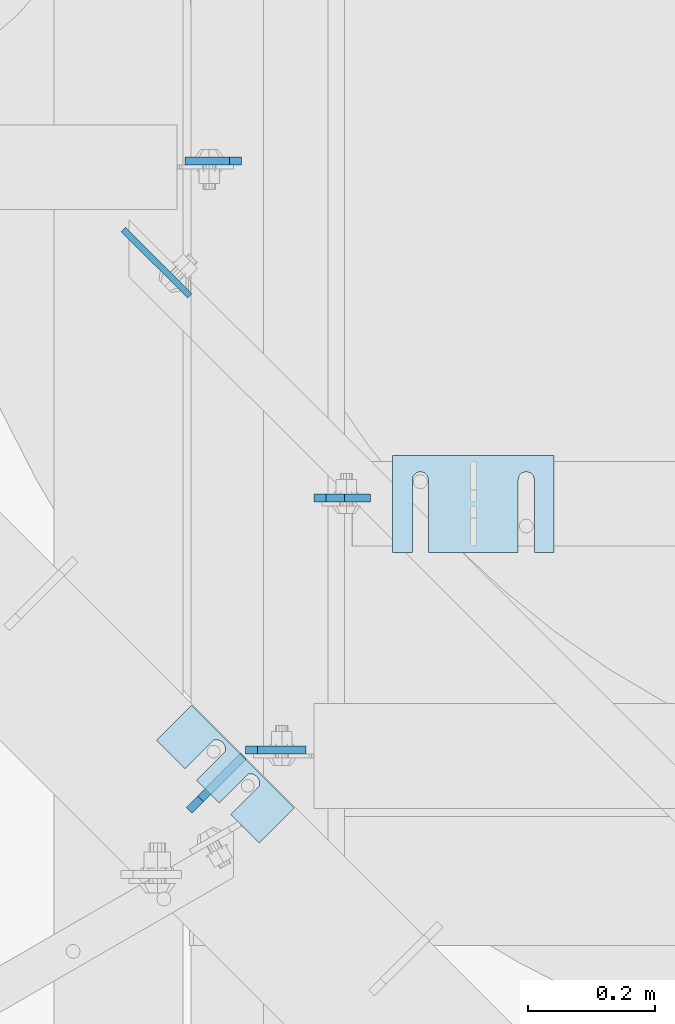
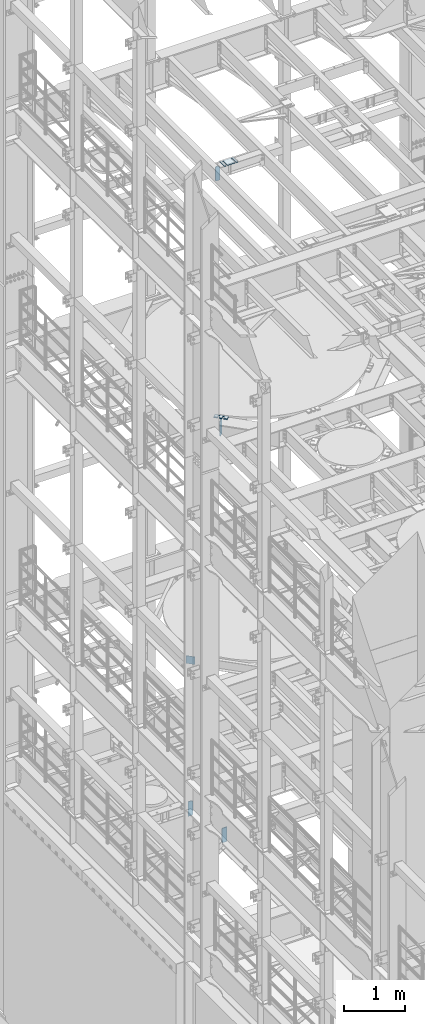
# One storey, part 1762 of 1876: 9 plates, 8 elements without a shape of their own.
"""IFC2X3 building model written with IfcOpenShell, lengths in millimetres."""

from ifc_helpers import new_model, si_unit, frame, origin_with_axes, place, context, subcontext, project, spatial, faceted_brep, material, type_object, element, aggregate, save


model = new_model("IFC2X3")

# Units and contexts
model_context = context("Model", 3, precision=1e-05, world=origin_with_axes())
body_context = subcontext(model_context, "Body", "Model", "MODEL_VIEW")
ifc_project = project(units=[si_unit("LENGTHUNIT", "METRE", prefix="MILLI"), si_unit("AREAUNIT", "SQUARE_METRE"), si_unit("VOLUMEUNIT", "CUBIC_METRE"), si_unit("MASSUNIT", "GRAM", prefix="KILO"), si_unit("TIMEUNIT", "SECOND"), si_unit("PLANEANGLEUNIT", "RADIAN"), si_unit("SOLIDANGLEUNIT", "STERADIAN"), si_unit("THERMODYNAMICTEMPERATUREUNIT", "DEGREE_CELSIUS"), si_unit("LUMINOUSINTENSITYUNIT", "LUMEN")], contexts=[model_context])

# Site, building, storey
site_placement = place(None, origin_with_axes())
site = spatial("IfcSite", under=ifc_project, at=site_placement, CompositionType="ELEMENT")
building_placement = place(site_placement, origin_with_axes())
building = spatial("IfcBuilding", under=site, at=building_placement, Name="Undefined", CompositionType="ELEMENT")
storey_placement = place(building_placement, origin_with_axes())
storey = spatial("IfcBuildingStorey", under=building, at=storey_placement, Name="Undefined", CompositionType="ELEMENT", Elevation=0.0)

# Assembly, plate
assembly_1_placement = place(storey_placement, origin_with_axes())
assembly_1 = element("IfcElementAssembly", 1, at=assembly_1_placement, inside=storey, Name="BEAM", AssemblyPlace="NOTDEFINED", PredefinedType="RIGID_FRAME")
ifc_material = material(Name="STEEL/A36")
plate_type_1 = type_object("IfcPlateType", PredefinedType="NOTDEFINED")
plate_1_placement = place(assembly_1_placement, frame((1933.575, 10521.9476197243, 17686.3375), z_axis=(0.0, 0.0, 1.0), x_axis=(1.0, 0.0, 0.0)))
plate_1 = element("IfcPlate", 2, at=plate_1_placement, type_object=plate_type_1, material=ifc_material, Name="PLATE", context=body_context, shape_type="Brep", body=[
    faceted_brep([(0.0, -6.35000000000036, 271.462512969971), (19.0499992370605, -6.35000000000036, 290.512512207031), (19.0499992370605, 6.35000000000036, 290.512512207031), (0.0, 6.35000000000036, 271.462512969971), (0.0, -6.35000000000196, 19.0499992370605), (0.0, 6.35000000000105, 19.0499992370605), (19.0499992370642, -6.35000000000105, 0.0), (19.0499992370633, 6.35000000000105, 0.0), (88.9000015258789, -6.34999999999991, 0.0), (88.9000015258789, 6.34999999999991, 0.0), (88.9000015258789, -6.35000000000036, 249.237510681152), (47.625, -6.35000000000036, 290.512512207031), (47.625, 6.35000000000036, 290.512512207031), (88.9000015258789, 6.35000000000036, 249.237510681152)], [[[0, 1, 2, 3]], [[4, 0, 3, 5]], [[6, 4, 5, 7]], [[8, 6, 7, 9]], [[6, 8, 10, 11, 1, 0, 4]], [[1, 11, 12, 2]], [[2, 12, 13, 9, 7, 5, 3]], [[10, 8, 9, 13]], [[11, 10, 13, 12]]]),
])
aggregate(assembly_1, [plate_1])

# Assembly, plates
assembly_2_placement = place(storey_placement, origin_with_axes())
assembly_2 = element("IfcElementAssembly", 3, at=assembly_2_placement, inside=storey, Name="BEAM", AssemblyPlace="NOTDEFINED", PredefinedType="RIGID_FRAME")
plate_2_placement = place(assembly_2_placement, frame((1819.275, 11052.1750000954, 4829.175), z_axis=(0.0, 0.0, 1.0), x_axis=(-1.0, 0.0, 0.0)))
plate_2 = element("IfcPlate", 4, at=plate_2_placement, type_object=plate_type_1, material=ifc_material, Name="PLATE", context=body_context, shape_type="Brep", body=[
    faceted_brep([(0.0, -6.35000000000196, 19.0499992370605), (0.0, -6.35000000000036, 271.462512969971), (0.0, 6.35000000000036, 271.462512969971), (0.0, 6.35000000000105, 19.0499992370605), (19.0499992370605, -6.35000000000036, 290.512512207031), (19.0499992370605, 6.35000000000036, 290.512512207031), (88.9000015258789, -6.35000000000036, 290.512512207031), (88.9000015258789, 6.35000000000036, 290.512512207031), (88.9000015258789, -6.34999999999991, 0.0), (88.9000015258789, 6.34999999999991, 0.0), (19.0499992370642, -6.35000000000105, 0.0), (19.0499992370633, 6.35000000000105, 0.0)], [[[0, 1, 2, 3]], [[1, 4, 5, 2]], [[4, 6, 7, 5]], [[6, 8, 9, 7]], [[8, 10, 11, 9]], [[10, 0, 3, 11]], [[5, 7, 9, 11, 3, 2]], [[10, 8, 6, 4, 1, 0]]]),
])
plate_type_2 = type_object("IfcPlateType", PredefinedType="NOTDEFINED")
plate_3_placement = place(assembly_2_placement, frame((1825.625, 10125.0750000954, 4829.175), z_axis=(0.0, 0.0, 1.0), x_axis=(1.0, 0.0, 0.0)))
plate_3 = element("IfcPlate", 5, at=plate_3_placement, type_object=plate_type_2, material=ifc_material, Name="PLATE", context=body_context, shape_type="Brep", body=[
    faceted_brep([(0.0, -6.35000000000196, 19.0499992370605), (0.0, -6.35000000000036, 271.462512969971), (0.0, 6.35000000000036, 271.462512969971), (0.0, 6.35000000000105, 19.0499992370605), (19.0499992370605, -6.35000000000036, 290.512512207031), (19.0499992370605, 6.35000000000036, 290.512512207031), (95.25, -6.35000000000036, 290.512512207031), (95.25, 6.35000000000036, 290.512512207031), (95.25, -6.35000000000036, 0.0), (95.25, 6.35000000000036, 0.0), (19.0499992370642, -6.35000000000105, 0.0), (19.0499992370633, 6.35000000000105, 0.0)], [[[0, 1, 2, 3]], [[1, 4, 5, 2]], [[4, 6, 7, 5]], [[6, 8, 9, 7]], [[8, 10, 11, 9]], [[10, 0, 3, 11]], [[5, 7, 9, 11, 3, 2]], [[10, 8, 6, 4, 1, 0]]]),
])
aggregate(assembly_2, [plate_2, plate_3])

# Assembly, plate
assembly_3_placement = place(storey_placement, origin_with_axes())
assembly_3 = element("IfcElementAssembly", 6, at=assembly_3_placement, inside=storey, Name="BEAM", AssemblyPlace="NOTDEFINED", PredefinedType="RIGID_FRAME")
plate_type_3 = type_object("IfcPlateType", PredefinedType="NOTDEFINED")
plate_4_placement = place(assembly_3_placement, frame((1632.93539790545, 10944.7448640714, 8121.65), z_axis=(0.707305809668414, -0.706907696668602, 0.0), x_axis=(0.0, 0.0, -1.0)))
plate_4 = element("IfcPlate", 7, at=plate_4_placement, type_object=plate_type_3, material=ifc_material, Name="PLATE", context=body_context, shape_type="Brep", body=[
    faceted_brep([(0.0, -4.76249999999982, 0.0), (0.0, -4.76249999995343, 148.1358184815), (0.0, 4.76250000004256, 148.135818481504), (0.0, 4.76249999999982, 0.0), (152.399993896484, -4.76249999995343, 148.1358184815), (152.399993896484, 4.76250000004256, 148.135818481504), (152.399993896484, -4.76249999999982, 0.0), (152.399993896484, 4.76249999999982, 0.0)], [[[0, 1, 2, 3]], [[1, 4, 5, 2]], [[4, 6, 7, 5]], [[6, 0, 3, 7]], [[5, 7, 3, 2]], [[6, 4, 1, 0]]]),
])
aggregate(assembly_3, [plate_4])

assembly_4_placement = place(storey_placement, origin_with_axes())
assembly_4 = element("IfcElementAssembly", 8, at=assembly_4_placement, inside=storey, Name="SHIM PLATE", AssemblyPlace="NOTDEFINED", PredefinedType="RIGID_FRAME")
plate_type_4 = type_object("IfcPlateType", PredefinedType="NOTDEFINED")
plate_5_placement = place(assembly_4_placement, frame((1685.49921187468, 10140.2424941069, 13326.268), z_axis=(0.707124703959405, -0.707088857959397, 0.0), x_axis=(0.707088857959397, 0.707124703959405, 0.0)))
plate_5 = element("IfcPlate", 9, at=plate_5_placement, type_object=plate_type_4, material=ifc_material, Name="SHIM PLATE", context=body_context, shape_type="Brep", body=[
    faceted_brep([(-2.69435986410826e-07, -2.3809999999994, 88.9036802523951), (-2.69435986410826e-07, 2.3809999999994, 88.9036802523951), (64.2890073715644, 2.3809999999994, 88.9052190745733), (64.2890073715644, -2.3809999999994, 88.9052190745733), (69.5243873298787, 2.3809999999994, 83.491558410592), (69.5243873298787, -2.3809999999994, 83.491558410592), (64.2896161919234, -2.3809999999994, 63.5071916498646), (64.2896161919234, 2.3809999999994, 63.5071916498646), (-1.92456354852766e-07, 2.3809999999994, 63.5036806291737), (-1.92456354852766e-07, -2.3809999999994, 63.5036806291737), (69.5247366006934, -2.3809999999994, 68.9211033039355), (69.5247366006934, 2.3809999999994, 68.9211033039355), (71.4330651893342, -2.3809999999994, 76.2063766063084), (71.4330651893342, 2.3809999999994, 76.2063766063084), (64.2877911166179, -2.3809999999994, 139.707191628079), (64.2877911166179, 2.3809999999994, 139.707191628079), (-4.23391611548141e-07, 2.3809999999994, 139.703680607395), (-4.23391611548141e-07, -2.3809999999994, 139.703680607395), (69.522911525386, -2.3809999999994, 145.121103282152), (69.522911525386, 2.3809999999994, 145.121103282152), (71.4312401140269, -2.3809999999994, 152.406376584525), (71.4312401140269, 2.3809999999994, 152.406376584525), (69.5225622545713, -2.3809999999994, 159.691558388808), (69.5225622545713, 2.3809999999994, 159.691558388808), (64.2871822962588, -2.3809999999994, 165.105219052789), (64.2871822962588, 2.3809999999994, 165.105219052789), (-5.00371243106201e-07, -2.3809999999994, 165.103680230615), (-5.00371243106201e-07, 2.3809999999994, 165.103680230615), (-6.92813046043739e-07, -2.3809999999994, 228.601303100699), (-6.92813046043739e-07, 2.3809999999994, 228.601303100699), (78.1460113524699, -2.3809999999994, 228.601303100651), (78.1460113524699, 2.3809999999994, 228.601303100651), (78.1460113525918, -2.3809999999994, -4.72937244921923e-11), (78.1460113525918, 2.3809999999994, -4.72937244921923e-11), (0.0, -2.38100000000122, 4.54747350886464e-13), (0.0, 2.38100000000122, 4.54747350886464e-13)], [[[0, 1, 2, 3]], [[3, 2, 4, 5]], [[6, 7, 8, 9]], [[10, 11, 7, 6]], [[12, 13, 11, 10]], [[5, 4, 13, 12]], [[14, 15, 16, 17]], [[18, 19, 15, 14]], [[20, 21, 19, 18]], [[22, 23, 21, 20]], [[24, 25, 23, 22]], [[26, 27, 25, 24]], [[28, 29, 27, 26]], [[28, 30, 31, 29]], [[30, 32, 33, 31]], [[32, 34, 35, 33]], [[35, 34, 9, 8]], [[2, 1, 16, 15, 19, 21, 23, 25, 27, 29, 31, 33, 35, 8, 7, 11, 13, 4]], [[17, 16, 1, 0]], [[6, 9, 34, 32, 30, 28, 26, 24, 22, 20, 18, 14, 17, 0, 3, 5, 12, 10]]]),
])
aggregate(assembly_4, [plate_5])

assembly_5_placement = place(storey_placement, origin_with_axes())
assembly_5 = element("IfcElementAssembly", 10, at=assembly_5_placement, inside=storey, Name="SHIM PLATE", AssemblyPlace="NOTDEFINED", PredefinedType="RIGID_FRAME")
plate_6_placement = place(assembly_5_placement, frame((1685.49921187468, 10140.2424941069, 13321.506), z_axis=(0.707124703959405, -0.707088857959397, 0.0), x_axis=(0.707088857959397, 0.707124703959405, 0.0)))
plate_6 = element("IfcPlate", 11, at=plate_6_placement, type_object=plate_type_4, material=ifc_material, Name="SHIM PLATE", context=body_context, shape_type="Brep", body=[
    faceted_brep([(-2.69435986410826e-07, -2.3809999999994, 88.9036802523951), (-2.69435986410826e-07, 2.3809999999994, 88.9036802523951), (64.2890073715644, 2.3809999999994, 88.9052190745733), (64.2890073715644, -2.3809999999994, 88.9052190745733), (69.5243873298787, 2.3809999999994, 83.491558410592), (69.5243873298787, -2.3809999999994, 83.491558410592), (64.2896161919234, -2.3809999999994, 63.5071916498646), (64.2896161919234, 2.3809999999994, 63.5071916498646), (-1.92456354852766e-07, 2.3809999999994, 63.5036806291737), (-1.92456354852766e-07, -2.3809999999994, 63.5036806291737), (69.5247366006934, -2.3809999999994, 68.9211033039355), (69.5247366006934, 2.3809999999994, 68.9211033039355), (71.4330651893342, -2.3809999999994, 76.2063766063084), (71.4330651893342, 2.3809999999994, 76.2063766063084), (64.2877911166179, -2.3809999999994, 139.707191628079), (64.2877911166179, 2.3809999999994, 139.707191628079), (-4.23391611548141e-07, 2.3809999999994, 139.703680607395), (-4.23391611548141e-07, -2.3809999999994, 139.703680607395), (69.522911525386, -2.3809999999994, 145.121103282152), (69.522911525386, 2.3809999999994, 145.121103282152), (71.4312401140269, -2.3809999999994, 152.406376584525), (71.4312401140269, 2.3809999999994, 152.406376584525), (69.5225622545713, -2.3809999999994, 159.691558388808), (69.5225622545713, 2.3809999999994, 159.691558388808), (64.2871822962588, -2.3809999999994, 165.105219052789), (64.2871822962588, 2.3809999999994, 165.105219052789), (-5.00371243106201e-07, -2.3809999999994, 165.103680230615), (-5.00371243106201e-07, 2.3809999999994, 165.103680230615), (-6.92813046043739e-07, -2.3809999999994, 228.601303100699), (-6.92813046043739e-07, 2.3809999999994, 228.601303100699), (78.1460113524699, -2.3809999999994, 228.601303100651), (78.1460113524699, 2.3809999999994, 228.601303100651), (78.1460113525918, -2.3809999999994, -4.72937244921923e-11), (78.1460113525918, 2.3809999999994, -4.72937244921923e-11), (0.0, -2.38100000000122, 4.54747350886464e-13), (0.0, 2.38100000000122, 4.54747350886464e-13)], [[[0, 1, 2, 3]], [[3, 2, 4, 5]], [[6, 7, 8, 9]], [[10, 11, 7, 6]], [[12, 13, 11, 10]], [[5, 4, 13, 12]], [[14, 15, 16, 17]], [[18, 19, 15, 14]], [[20, 21, 19, 18]], [[22, 23, 21, 20]], [[24, 25, 23, 22]], [[26, 27, 25, 24]], [[28, 29, 27, 26]], [[28, 30, 31, 29]], [[30, 32, 33, 31]], [[32, 34, 35, 33]], [[35, 34, 9, 8]], [[2, 1, 16, 15, 19, 21, 23, 25, 27, 29, 31, 33, 35, 8, 7, 11, 13, 4]], [[17, 16, 1, 0]], [[6, 9, 34, 32, 30, 28, 26, 24, 22, 20, 18, 14, 17, 0, 3, 5, 12, 10]]]),
])
aggregate(assembly_5, [plate_6])

assembly_6_placement = place(storey_placement, origin_with_axes())
assembly_6 = element("IfcElementAssembly", 12, at=assembly_6_placement, inside=storey, Name="SHIM PLATE", AssemblyPlace="NOTDEFINED", PredefinedType="RIGID_FRAME")
plate_type_5 = type_object("IfcPlateType", PredefinedType="NOTDEFINED")
plate_7_placement = place(assembly_6_placement, frame((1685.49921187468, 10140.2424941069, 13314.3625), z_axis=(0.707124703959405, -0.707088857959397, 0.0), x_axis=(0.707088857959397, 0.707124703959405, 0.0)))
plate_7 = element("IfcPlate", 13, at=plate_7_placement, type_object=plate_type_5, material=ifc_material, Name="SHIM PLATE", context=body_context, shape_type="Brep", body=[
    faceted_brep([(-2.69435986410826e-07, -4.76250000000073, 88.9036802523951), (-2.69435986410826e-07, 4.76250000000073, 88.9036802523951), (64.2890073715644, 4.76250000000073, 88.9052190745733), (64.2890073715644, -4.76250000000073, 88.9052190745733), (69.5243873298787, 4.76250000000073, 83.491558410592), (69.5243873298787, -4.76250000000073, 83.491558410592), (64.2896161919234, -4.76250000000073, 63.5071916498646), (64.2896161919234, 4.76250000000073, 63.5071916498646), (-1.92456354852766e-07, 4.76250000000073, 63.5036806291737), (-1.92456354852766e-07, -4.76250000000073, 63.5036806291737), (69.5247366006934, -4.76250000000073, 68.9211033039355), (69.5247366006934, 4.76250000000073, 68.9211033039355), (71.4330651893342, -4.76250000000073, 76.2063766063084), (71.4330651893342, 4.76250000000073, 76.2063766063084), (64.2877911166179, -4.76250000000073, 139.707191628079), (64.2877911166179, 4.76250000000073, 139.707191628079), (-4.23391611548141e-07, 4.76250000000073, 139.703680607395), (-4.23391611548141e-07, -4.76250000000073, 139.703680607395), (69.522911525386, -4.76250000000073, 145.121103282152), (69.522911525386, 4.76250000000073, 145.121103282152), (71.4312401140269, -4.76250000000073, 152.406376584525), (71.4312401140269, 4.76250000000073, 152.406376584525), (69.5225622545713, -4.76250000000073, 159.691558388808), (69.5225622545713, 4.76250000000073, 159.691558388808), (64.2871822962588, -4.76250000000073, 165.105219052789), (64.2871822962588, 4.76250000000073, 165.105219052789), (-5.00371243106201e-07, -4.76250000000073, 165.103680230615), (-5.00371243106201e-07, 4.76250000000073, 165.103680230615), (-6.92813046043739e-07, -4.76250000000073, 228.601303100699), (-6.92813046043739e-07, 4.76250000000073, 228.601303100699), (78.1460113524699, -4.76250000000073, 228.601303100651), (78.1460113524699, 4.76250000000073, 228.601303100651), (78.1460113525918, -4.76250000000073, -4.72937244921923e-11), (78.1460113525918, 4.76250000000073, -4.72937244921923e-11), (0.0, -4.76249999999982, 0.0), (0.0, 4.76249999999982, 0.0)], [[[0, 1, 2, 3]], [[3, 2, 4, 5]], [[6, 7, 8, 9]], [[10, 11, 7, 6]], [[12, 13, 11, 10]], [[5, 4, 13, 12]], [[14, 15, 16, 17]], [[18, 19, 15, 14]], [[20, 21, 19, 18]], [[22, 23, 21, 20]], [[24, 25, 23, 22]], [[26, 27, 25, 24]], [[28, 29, 27, 26]], [[28, 30, 31, 29]], [[30, 32, 33, 31]], [[32, 34, 35, 33]], [[35, 34, 9, 8]], [[2, 1, 16, 15, 19, 21, 23, 25, 27, 29, 31, 33, 35, 8, 7, 11, 13, 4]], [[17, 16, 1, 0]], [[6, 9, 34, 32, 30, 28, 26, 24, 22, 20, 18, 14, 17, 0, 3, 5, 12, 10]]]),
])
aggregate(assembly_6, [plate_7])

assembly_7_placement = place(storey_placement, origin_with_axes())
assembly_7 = element("IfcElementAssembly", 14, at=assembly_7_placement, inside=storey, Name="SHIM PLATE", AssemblyPlace="NOTDEFINED", PredefinedType="RIGID_FRAME")
plate_type_6 = type_object("IfcPlateType", PredefinedType="NOTDEFINED")
plate_8_placement = place(assembly_7_placement, frame((2311.41072536354, 10588.6220636394, 17987.9625), z_axis=(0.0, -1.0, 0.0), x_axis=(-1.0, 0.0, 0.0)))
plate_8 = element("IfcPlate", 15, at=plate_8_placement, type_object=plate_type_6, material=ifc_material, Name="SHIM PLATE", context=body_context, shape_type="Brep", body=[
    faceted_brep([(30.8791924037423, -4.76250000000073, 152.398895263674), (30.8814140421409, -4.76250000000073, 38.0994505407325), (30.8814140421409, 4.76250000000073, 38.0994505407325), (30.8791924037423, 4.76250000000073, 152.398895263674), (32.5828868936751, -4.76250000000073, 31.7494480341243), (32.5828868936751, 4.76250000000073, 31.7494480341243), (37.2314075583954, -4.76250000000073, 27.1009216732054), (37.2314075583954, 4.76250000000073, 27.1009216732054), (43.5814079800521, -4.76250000000073, 25.3994410405157), (43.5814079800521, 4.76250000000073, 25.3994410405157), (49.9314097200559, -4.76250000000073, 27.1009167530574), (49.9314097200559, 4.76250000000073, 27.1009167530574), (54.5799339865616, -4.76250000000073, 31.7494395121785), (54.5799339865616, 4.76250000000073, 31.7494395121785), (56.2814117582284, -4.76250000000073, 38.0994407004391), (56.2814117582284, 4.76250000000073, 38.0994407004391), (56.2791901197206, -4.76250000000073, 152.398894414155), (56.2791901197206, 4.76250000000073, 152.398895263676), (0.0, -4.76249999999982, 0.0), (1.98255729628727e-05, -4.76250000000073, 152.398895263672), (1.98255729628727e-05, 4.76250000000073, 152.398895263672), (0.0, 4.76249999999982, 0.0), (253.999542236328, -4.76250000000073, 6.16182660451159e-11), (253.999542236328, 4.76250000000073, 6.16182660451159e-11), (253.999557495107, -4.76250000000073, 152.398895263688), (253.999557495107, 4.76250000000073, 152.398895263688), (223.116882380463, 4.76250000000073, 152.398895263686), (223.116882380463, -4.76250000000073, 152.398895415181), (223.119104018971, 4.76250000000073, 38.0994417014649), (223.119104018971, -4.76250000000073, 38.0994417014649), (221.417626247304, 4.76250000000073, 31.7494405132047), (221.417626247304, -4.76250000000073, 31.7494405132047), (216.769101980798, 4.76250000000073, 27.1009177540836), (216.769101980798, -4.76250000000073, 27.1009177540836), (210.419100240794, 4.76250000000073, 25.399442041542), (210.419100240794, -4.76250000000073, 25.399442041542), (204.069099819138, 4.76250000000073, 27.1009226742317), (204.069099819138, -4.76250000000073, 27.1009226742317), (199.420579154417, 4.76250000000073, 31.7494490351505), (199.420579154417, -4.76250000000073, 31.7494490351505), (197.719106302883, 4.76250000000073, 38.0994515417583), (197.719106302883, -4.76250000000073, 38.0994515417583), (197.716884664484, -4.76250000000073, 152.398895263684), (197.716884664484, 4.76250000000073, 152.398895263684)], [[[0, 1, 2, 3]], [[4, 5, 2, 1]], [[6, 7, 5, 4]], [[8, 9, 7, 6]], [[10, 11, 9, 8]], [[12, 13, 11, 10]], [[14, 15, 13, 12]], [[16, 17, 15, 14]], [[18, 19, 20, 21]], [[22, 18, 21, 23]], [[24, 22, 23, 25]], [[24, 25, 26, 27]], [[27, 26, 28, 29]], [[29, 28, 30, 31]], [[31, 30, 32, 33]], [[33, 32, 34, 35]], [[35, 34, 36, 37]], [[37, 36, 38, 39]], [[39, 38, 40, 41]], [[42, 41, 40, 43]], [[12, 10, 8, 6, 4, 1, 0, 19, 18, 22, 24, 27, 29, 31, 33, 35, 37, 39, 41, 42, 16, 14]], [[20, 19, 0, 3]], [[43, 40, 38, 36, 34, 32, 30, 28, 26, 25, 23, 21, 20, 3, 2, 5, 7, 9, 11, 13, 15, 17]], [[42, 43, 17, 16]]]),
])
aggregate(assembly_7, [plate_8])

assembly_8_placement = place(storey_placement, origin_with_axes())
assembly_8 = element("IfcElementAssembly", 16, at=assembly_8_placement, inside=storey, Name="BEAM", AssemblyPlace="NOTDEFINED", PredefinedType="RIGID_FRAME")
plate_type_7 = type_object("IfcPlateType", PredefinedType="NOTDEFINED")
plate_9_placement = place(assembly_8_placement, frame((1822.04298606175, 10115.1455676181, 12973.0500000172), z_axis=(0.0, 0.0, 1.0), x_axis=(-0.707106781186547, -0.707106781186548, 0.0)))
plate_9 = element("IfcPlate", 17, at=plate_9_placement, type_object=plate_type_7, material=ifc_material, Name="PLATE", context=body_context, shape_type="Brep", body=[
    faceted_brep([(0.0, -6.35000000000036, 0.0), (1.81898940354586e-12, -6.35000000000127, 317.5), (0.0, 6.35000000000036, 317.5), (0.0, 6.35000000000036, 0.0), (95.25, -6.35000000000036, 317.5), (95.25, 6.35000000000036, 317.5), (120.650001525877, -6.34999999998126, 292.10000038147), (120.650001525881, 6.35000000001855, 292.10000038147), (120.650001525877, -6.34999999998126, 25.3999996185303), (120.650001525881, 6.35000000001855, 25.3999996185303), (95.25, -6.35000000000036, 0.0), (95.25, 6.35000000000036, 0.0)], [[[0, 1, 2, 3]], [[1, 4, 5, 2]], [[4, 6, 7, 5]], [[6, 8, 9, 7]], [[8, 10, 11, 9]], [[10, 0, 3, 11]], [[5, 7, 9, 11, 3, 2]], [[10, 8, 6, 4, 1, 0]]]),
])
aggregate(assembly_8, [plate_9])

save(model, "model.ifc")
